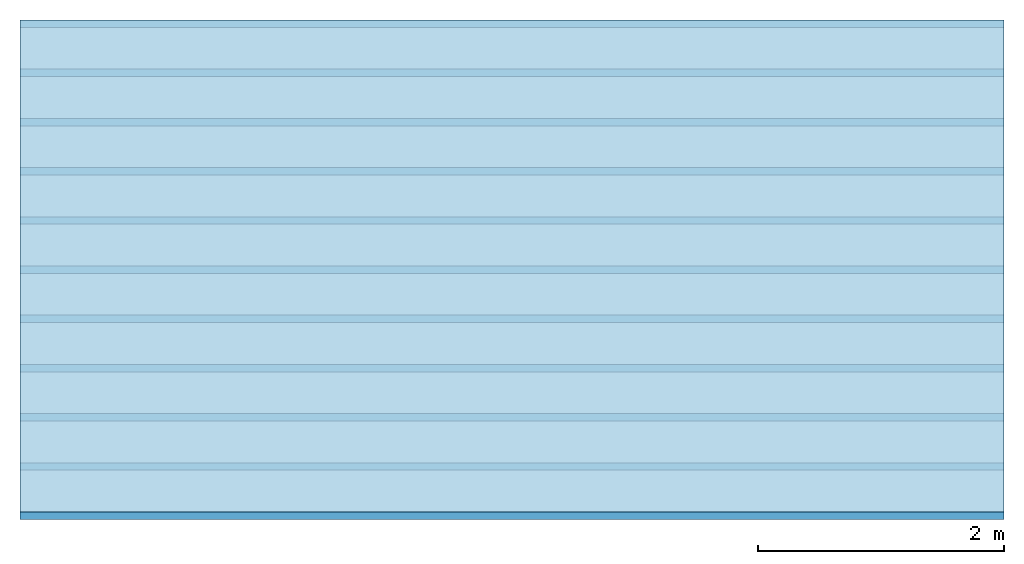
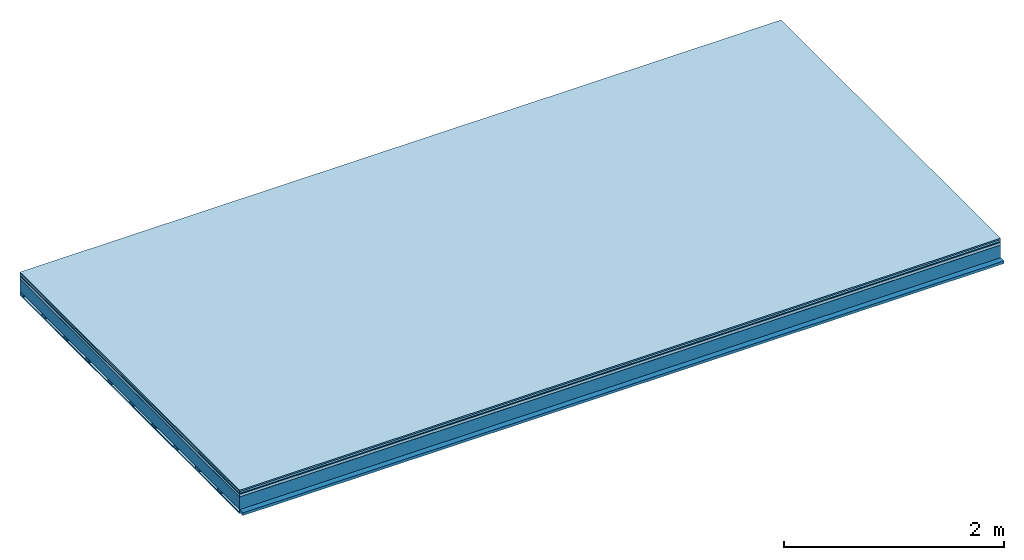
# One storey: 7 plates, 2 members, 1 element without a shape of its own.
"""IFC4 building model written with IfcOpenShell, lengths in metres."""

from ifc_helpers import new_model, si_unit, derived_unit, direction, frame, frame_2d, origin, origin_with_axes, place, context, project, spatial, rectangle, extrude, material, layer, layer_set, type_object, element, aggregate, save


model = new_model("IFC4")

# Units and contexts
plan_context = context("Plan", 3, precision=1e-05, world=origin(), true_north=direction((0.0, 1.0)))
model_context = context("Model", 3, precision=1e-05, world=origin(), true_north=direction((0.0, 1.0)))
ifc_project = project(units=[si_unit("LENGTHUNIT", "METRE"), derived_unit("SOUNDPRESSUREUNIT", [(si_unit("PRESSUREUNIT", "PASCAL", prefix="MICRO"), 0)]), si_unit("ENERGYUNIT", "JOULE", prefix="MEGA"), si_unit("MASSUNIT", "GRAM", prefix="KILO"), derived_unit("THERMALTRANSMITTANCEUNIT", [(si_unit("POWERUNIT", "WATT"), 1), (si_unit("AREAUNIT", "SQUARE_METRE"), -1), (si_unit("THERMODYNAMICTEMPERATUREUNIT", "KELVIN"), -1)]), derived_unit("AREADENSITYUNIT", [(si_unit("MASSUNIT", "GRAM", prefix="KILO"), 1), (si_unit("AREAUNIT", "SQUARE_METRE"), -1)]), derived_unit("USERDEFINED", [(si_unit("ENERGYUNIT", "JOULE", prefix="MEGA"), 1), (si_unit("AREAUNIT", "SQUARE_METRE"), -1)])], contexts=[plan_context, model_context])

# Site, building, storey
site = spatial("IfcSite", under=ifc_project)
building_placement = place(None, origin())
building = spatial("IfcBuilding", under=site, at=building_placement)
storey_placement = place(building_placement, origin())
storey = spatial("IfcBuildingStorey", under=building, at=storey_placement)

# Slab, members, plates
ifc_material_1 = material(Category="11.013")
ifc_layer_1 = layer(ifc_material_1, 0.015, Name="Flooring")
ifc_material_2 = material(Category="03.007")
ifc_layer_2 = layer(ifc_material_2, 0.02, Name="On-material")
ifc_material_3 = material(Name="Wood fiber generic product", Category="10.009")
ifc_layer_3 = layer(ifc_material_3, 0.01, Name="Impact sound insulation")
ifc_material_4 = material(Name="with broken")
ifc_layer_4 = layer(ifc_material_4, 0.03, Name="on Supporting structure")
ifc_material_5 = material(Name="protection", Category="09.007")
ifc_layer_5 = layer(ifc_material_5, 0.0005, Name="Sub-floor")
ifc_material_6 = material(Name="no composite action")
ifc_layer_6 = layer(ifc_material_6, 0.0, Name="Bond")
ifc_layer_7 = layer(None, 0.14, Name="Supporting structure")
ifc_material_7 = material(Name="of the art")
ifc_layer_8 = layer(ifc_material_7, 0.0, Name="Bond")
ifc_layer_9 = layer(None, 0.03, Name="Battens / profiles")
ifc_material_8 = material(Name="Plasterboard type A", Category="03.008")
ifc_layer_10 = layer(ifc_material_8, 0.0125, Name="Ceiling covering 1st layer")
ifc_material_9 = material(Category="04.001")
ifc_layer_11 = layer(ifc_material_9, 0.003, Name="Surface / treatment")
ifc_layer_set = layer_set([ifc_layer_1, ifc_layer_2, ifc_layer_3, ifc_layer_4, ifc_layer_5, ifc_layer_6, ifc_layer_7, ifc_layer_8, ifc_layer_9, ifc_layer_10, ifc_layer_11])
slab_type = type_object("IfcSlabType", Name="A2106", PredefinedType="NOTDEFINED", material=ifc_layer_set)
slab_placement = place(None, frame((0.0, 0.0, 0.0), z_axis=(0.0, 0.0, -1.0), x_axis=(1.0, 0.0, 0.0)))
slab = element("IfcSlab", 1, at=slab_placement, inside=storey, type_object=slab_type, material=ifc_layer_set, Name="Slab #1")
ifc_material_10 = material(Name="Solid timber panel")
member_1_placement = place(slab_placement, origin())
member_1 = element("IfcMember", 2, at=member_1_placement, material=ifc_material_10, Name="Supporting structure", context=plan_context, shape_type="SweptSolid", body=[
    extrude(rectangle(XDim=1.0, YDim=0.14, at=frame_2d((0.5, 0.07), x_axis=(1.0, 0.0))), frame((0.0, 4.0, 0.0755), z_axis=(0.0, -1.0, 0.0), x_axis=(1.0, 0.0, 0.0)), (0.0, 0.0, 1.0), 4.0),
    extrude(rectangle(XDim=1.0, YDim=0.14, at=frame_2d((0.5, 0.07), x_axis=(1.0, 0.0))), frame((1.0, 4.0, 0.0755), z_axis=(0.0, -1.0, 0.0), x_axis=(1.0, 0.0, 0.0)), (0.0, 0.0, 1.0), 4.0),
    extrude(rectangle(XDim=1.0, YDim=0.14, at=frame_2d((0.5, 0.07), x_axis=(1.0, 0.0))), frame((2.0, 4.0, 0.0755), z_axis=(0.0, -1.0, 0.0), x_axis=(1.0, 0.0, 0.0)), (0.0, 0.0, 1.0), 4.0),
    extrude(rectangle(XDim=1.0, YDim=0.14, at=frame_2d((0.5, 0.07), x_axis=(1.0, 0.0))), frame((3.0, 4.0, 0.0755), z_axis=(0.0, -1.0, 0.0), x_axis=(1.0, 0.0, 0.0)), (0.0, 0.0, 1.0), 4.0),
    extrude(rectangle(XDim=1.0, YDim=0.14, at=frame_2d((0.5, 0.07), x_axis=(1.0, 0.0))), frame((4.0, 4.0, 0.0755), z_axis=(0.0, -1.0, 0.0), x_axis=(1.0, 0.0, 0.0)), (0.0, 0.0, 1.0), 4.0),
    extrude(rectangle(XDim=1.0, YDim=0.14, at=frame_2d((0.5, 0.07), x_axis=(1.0, 0.0))), frame((5.0, 4.0, 0.0755), z_axis=(0.0, -1.0, 0.0), x_axis=(1.0, 0.0, 0.0)), (0.0, 0.0, 1.0), 4.0),
    extrude(rectangle(XDim=1.0, YDim=0.14, at=frame_2d((0.5, 0.07), x_axis=(1.0, 0.0))), frame((6.0, 4.0, 0.0755), z_axis=(0.0, -1.0, 0.0), x_axis=(1.0, 0.0, 0.0)), (0.0, 0.0, 1.0), 4.0),
    extrude(rectangle(XDim=1.0, YDim=0.14, at=frame_2d((0.5, 0.07), x_axis=(1.0, 0.0))), frame((7.0, 4.0, 0.0755), z_axis=(0.0, -1.0, 0.0), x_axis=(1.0, 0.0, 0.0)), (0.0, 0.0, 1.0), 4.0),
])
ifc_material_11 = material()
member_2_placement = place(slab_placement, origin())
member_2 = element("IfcMember", 3, at=member_2_placement, material=ifc_material_11, Name="Battens / profiles", context=plan_context, shape_type="SweptSolid", body=[
    extrude(rectangle(XDim=0.06, YDim=0.03, at=frame_2d((0.03, 0.015), x_axis=(1.0, 0.0))), frame((0.0, 0.0, 0.2155), z_axis=(1.0, 0.0, 0.0), x_axis=(0.0, 1.0, 0.0)), (0.0, 0.0, 1.0), 8.0),
    extrude(rectangle(XDim=0.06, YDim=0.03, at=frame_2d((0.03, 0.015), x_axis=(1.0, 0.0))), frame((0.0, 0.4, 0.2155), z_axis=(1.0, 0.0, 0.0), x_axis=(0.0, 1.0, 0.0)), (0.0, 0.0, 1.0), 8.0),
    extrude(rectangle(XDim=0.06, YDim=0.03, at=frame_2d((0.03, 0.015), x_axis=(1.0, 0.0))), frame((0.0, 0.8, 0.2155), z_axis=(1.0, 0.0, 0.0), x_axis=(0.0, 1.0, 0.0)), (0.0, 0.0, 1.0), 8.0),
    extrude(rectangle(XDim=0.06, YDim=0.03, at=frame_2d((0.03, 0.015), x_axis=(1.0, 0.0))), frame((0.0, 1.2, 0.2155), z_axis=(1.0, 0.0, 0.0), x_axis=(0.0, 1.0, 0.0)), (0.0, 0.0, 1.0), 8.0),
    extrude(rectangle(XDim=0.06, YDim=0.03, at=frame_2d((0.03, 0.015), x_axis=(1.0, 0.0))), frame((0.0, 1.6, 0.2155), z_axis=(1.0, 0.0, 0.0), x_axis=(0.0, 1.0, 0.0)), (0.0, 0.0, 1.0), 8.0),
    extrude(rectangle(XDim=0.06, YDim=0.03, at=frame_2d((0.03, 0.015), x_axis=(1.0, 0.0))), frame((0.0, 2.0, 0.2155), z_axis=(1.0, 0.0, 0.0), x_axis=(0.0, 1.0, 0.0)), (0.0, 0.0, 1.0), 8.0),
    extrude(rectangle(XDim=0.06, YDim=0.03, at=frame_2d((0.03, 0.015), x_axis=(1.0, 0.0))), frame((0.0, 2.4, 0.2155), z_axis=(1.0, 0.0, 0.0), x_axis=(0.0, 1.0, 0.0)), (0.0, 0.0, 1.0), 8.0),
    extrude(rectangle(XDim=0.06, YDim=0.03, at=frame_2d((0.03, 0.015), x_axis=(1.0, 0.0))), frame((0.0, 2.8, 0.2155), z_axis=(1.0, 0.0, 0.0), x_axis=(0.0, 1.0, 0.0)), (0.0, 0.0, 1.0), 8.0),
    extrude(rectangle(XDim=0.06, YDim=0.03, at=frame_2d((0.03, 0.015), x_axis=(1.0, 0.0))), frame((0.0, 3.2, 0.2155), z_axis=(1.0, 0.0, 0.0), x_axis=(0.0, 1.0, 0.0)), (0.0, 0.0, 1.0), 8.0),
    extrude(rectangle(XDim=0.06, YDim=0.03, at=frame_2d((0.03, 0.015), x_axis=(1.0, 0.0))), frame((0.0, 3.6, 0.2155), z_axis=(1.0, 0.0, 0.0), x_axis=(0.0, 1.0, 0.0)), (0.0, 0.0, 1.0), 8.0),
    extrude(rectangle(XDim=0.06, YDim=0.03, at=frame_2d((0.03, 0.015), x_axis=(1.0, 0.0))), frame((0.0, 4.0, 0.2155), z_axis=(1.0, 0.0, 0.0), x_axis=(0.0, 1.0, 0.0)), (0.0, 0.0, 1.0), 8.0),
])
plate_1_placement = place(slab_placement, origin())
plate_1 = element("IfcPlate", 4, at=plate_1_placement, material=ifc_material_1, Name="Flooring", context=plan_context, shape_type="SweptSolid", body=[
    extrude(rectangle(XDim=8.0, YDim=4.0, at=frame_2d((4.0, 2.0), x_axis=(1.0, 0.0))), origin_with_axes(), (0.0, 0.0, 1.0), 0.015),
])
plate_2_placement = place(slab_placement, origin())
plate_2 = element("IfcPlate", 5, at=plate_2_placement, material=ifc_material_2, Name="On-material", context=plan_context, shape_type="SweptSolid", body=[
    extrude(rectangle(XDim=8.0, YDim=4.0, at=frame_2d((4.0, 2.0), x_axis=(1.0, 0.0))), frame((0.0, 0.0, 0.015), z_axis=(0.0, 0.0, 1.0), x_axis=(1.0, 0.0, 0.0)), (0.0, 0.0, 1.0), 0.02),
])
plate_3_placement = place(slab_placement, origin())
plate_3 = element("IfcPlate", 6, at=plate_3_placement, material=ifc_material_3, Name="Impact sound insulation", context=plan_context, shape_type="SweptSolid", body=[
    extrude(rectangle(XDim=8.0, YDim=4.0, at=frame_2d((4.0, 2.0), x_axis=(1.0, 0.0))), frame((0.0, 0.0, 0.035), z_axis=(0.0, 0.0, 1.0), x_axis=(1.0, 0.0, 0.0)), (0.0, 0.0, 1.0), 0.01),
])
plate_4_placement = place(slab_placement, origin())
plate_4 = element("IfcPlate", 7, at=plate_4_placement, material=ifc_material_4, Name="on Supporting structure", context=plan_context, shape_type="SweptSolid", body=[
    extrude(rectangle(XDim=8.0, YDim=4.0, at=frame_2d((4.0, 2.0), x_axis=(1.0, 0.0))), frame((0.0, 0.0, 0.045), z_axis=(0.0, 0.0, 1.0), x_axis=(1.0, 0.0, 0.0)), (0.0, 0.0, 1.0), 0.03),
])
plate_5_placement = place(slab_placement, origin())
plate_5 = element("IfcPlate", 8, at=plate_5_placement, material=ifc_material_5, Name="Sub-floor", context=plan_context, shape_type="SweptSolid", body=[
    extrude(rectangle(XDim=8.0, YDim=4.0, at=frame_2d((4.0, 2.0), x_axis=(1.0, 0.0))), frame((0.0, 0.0, 0.075), z_axis=(0.0, 0.0, 1.0), x_axis=(1.0, 0.0, 0.0)), (0.0, 0.0, 1.0), 0.0005),
])
plate_6_placement = place(slab_placement, origin())
plate_6 = element("IfcPlate", 9, at=plate_6_placement, material=ifc_material_8, Name="Ceiling covering 1st layer", context=plan_context, shape_type="SweptSolid", body=[
    extrude(rectangle(XDim=8.0, YDim=4.0, at=frame_2d((4.0, 2.0), x_axis=(1.0, 0.0))), frame((0.0, 0.0, 0.2455), z_axis=(0.0, 0.0, 1.0), x_axis=(1.0, 0.0, 0.0)), (0.0, 0.0, 1.0), 0.0125),
])
plate_7_placement = place(slab_placement, origin())
plate_7 = element("IfcPlate", 10, at=plate_7_placement, material=ifc_material_9, Name="Surface / treatment", context=plan_context, shape_type="SweptSolid", body=[
    extrude(rectangle(XDim=8.0, YDim=4.0, at=frame_2d((4.0, 2.0), x_axis=(1.0, 0.0))), frame((0.0, 0.0, 0.258), z_axis=(0.0, 0.0, 1.0), x_axis=(1.0, 0.0, 0.0)), (0.0, 0.0, 1.0), 0.003),
])
aggregate(slab, [plate_1, plate_2, plate_3, plate_4, plate_5, member_1, member_2, plate_6, plate_7])

save(model, "model.ifc")
